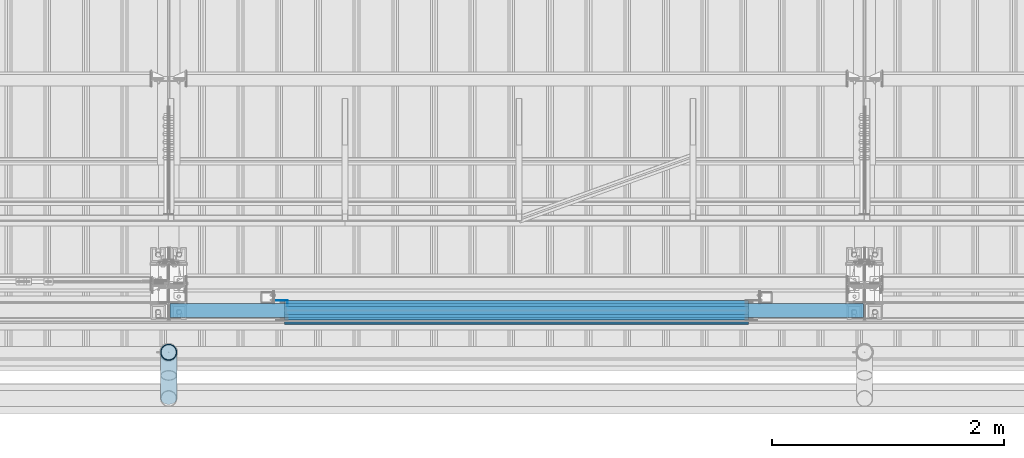
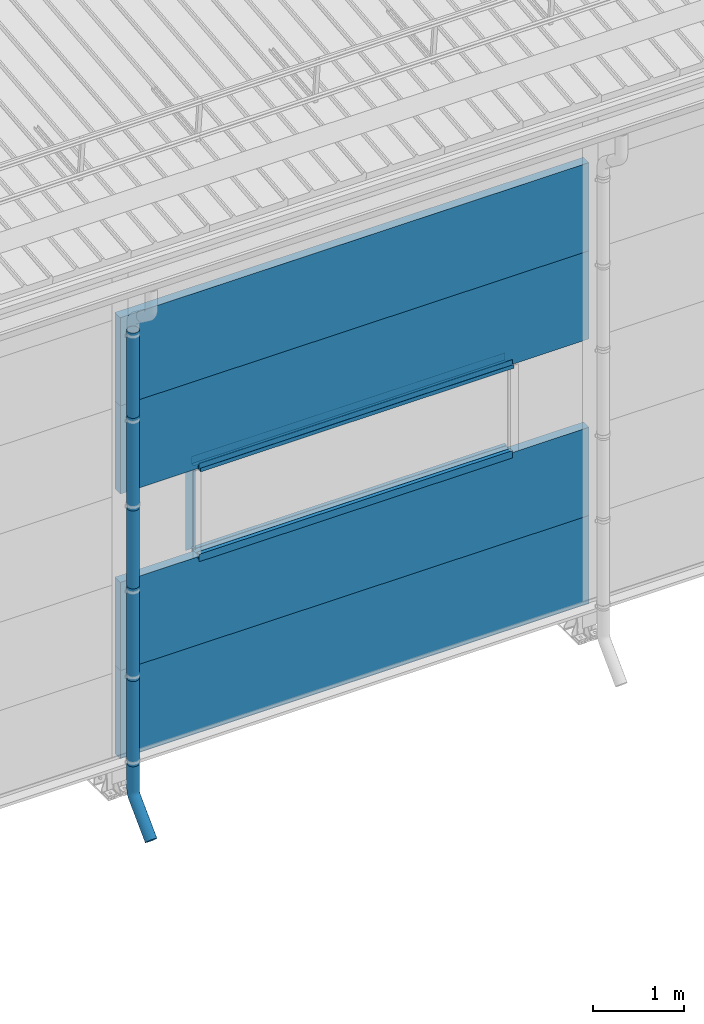
# One storey, part 45 of 709: 18 beams, 18 elements without a shape of their own.
"""IFC4 building model written with IfcOpenShell, lengths in millimetres."""

from ifc_helpers import new_model, entity, si_unit, direction, frame, origin_with_axes, place, context, subcontext, project, spatial, line, indexed_curve, outline, extrude, material, element, aggregate, save


model = new_model("IFC4")

# Units and contexts
model_context = context("Model", 3, precision=0.2, world=origin_with_axes(), true_north=direction((0.0, 1.0)))
body_context = subcontext(model_context, "Body", "Model", "MODEL_VIEW")
ifc_project = project(units=[si_unit("LENGTHUNIT", "METRE", prefix="MILLI"), si_unit("AREAUNIT", "SQUARE_METRE"), si_unit("VOLUMEUNIT", "CUBIC_METRE"), si_unit("MASSUNIT", "GRAM", prefix="KILO"), si_unit("TIMEUNIT", "SECOND"), si_unit("PLANEANGLEUNIT", "RADIAN"), si_unit("SOLIDANGLEUNIT", "STERADIAN"), si_unit("THERMODYNAMICTEMPERATUREUNIT", "DEGREE_CELSIUS"), si_unit("LUMINOUSINTENSITYUNIT", "LUMEN")], contexts=[model_context])

# Site, building, storey
site_placement = place(None, origin_with_axes())
site = spatial("IfcSite", under=ifc_project, at=site_placement, CompositionType="ELEMENT")
building_placement = place(site_placement, origin_with_axes())
building = spatial("IfcBuilding", under=site, at=building_placement, Name="Undefined", CompositionType="ELEMENT")
storey_placement = place(building_placement, origin_with_axes())
storey = spatial("IfcBuildingStorey", under=building, at=storey_placement, Name="Undefined", CompositionType="ELEMENT", Elevation=0.0)

# Assembly, beam
assembly_1_placement = place(storey_placement, frame((28010.0, -60.0, 895.0), z_axis=(0.0, 0.0, -1.0), x_axis=(1.0, 0.0, 0.0)))
assembly_1 = element("IfcElementAssembly", 1, at=assembly_1_placement, inside=storey)
ifc_material_1 = material(Name="Insulation", Category="Insulation")
beam_1_placement = place(assembly_1_placement, origin_with_axes())
beam_1 = element("IfcBeam", 2, at=beam_1_placement, material=ifc_material_1, ObjectType="P-107", context=body_context, shape_type="SolidModel", body=[
    extrude(outline(indexed_curve([(-595.0, -60.0), (595.0, -60.0), (595.0, 60.0), (-595.0, 60.0)], segments=[line(1, 2, 3, 4, 1)])), frame((0.0, 0.0, 0.0), z_axis=(-1.0, 0.0, 0.0), x_axis=(0.0, 0.0, 1.0)), (0.0, 0.0, -1.0), 5980.0),
])
aggregate(assembly_1, [beam_1])

assembly_2_placement = place(storey_placement, frame((28010.0, -60.0, 2085.0), z_axis=(0.0, 0.0, -1.0), x_axis=(1.0, 0.0, 0.0)))
assembly_2 = element("IfcElementAssembly", 3, at=assembly_2_placement, inside=storey)
beam_2_placement = place(assembly_2_placement, origin_with_axes())
beam_2 = element("IfcBeam", 4, at=beam_2_placement, material=ifc_material_1, ObjectType="P-107", context=body_context, shape_type="SolidModel", body=[
    extrude(outline(indexed_curve([(-595.0, -60.0), (595.0, -60.0), (595.0, 60.0), (-595.0, 60.0)], segments=[line(1, 2, 3, 4, 1)])), frame((0.0, 0.0, 0.0), z_axis=(-1.0, 0.0, 0.0), x_axis=(0.0, 0.0, 1.0)), (0.0, 0.0, -1.0), 5980.0),
])
aggregate(assembly_2, [beam_2])

assembly_3_placement = place(storey_placement, frame((28010.0, -60.0, 4465.0), z_axis=(0.0, 0.0, -1.0), x_axis=(1.0, 0.0, 0.0)))
assembly_3 = element("IfcElementAssembly", 5, at=assembly_3_placement, inside=storey)
beam_3_placement = place(assembly_3_placement, origin_with_axes())
beam_3 = element("IfcBeam", 6, at=beam_3_placement, material=ifc_material_1, ObjectType="P-107", context=body_context, shape_type="SolidModel", body=[
    extrude(outline(indexed_curve([(-595.0, -60.0), (595.0, -60.0), (595.0, 60.0), (-595.0, 60.0)], segments=[line(1, 2, 3, 4, 1)])), frame((0.0, 0.0, 0.0), z_axis=(-1.0, 0.0, 0.0), x_axis=(0.0, 0.0, 1.0)), (0.0, 0.0, -1.0), 5980.0),
])
aggregate(assembly_3, [beam_3])

assembly_4_placement = place(storey_placement, frame((28010.0, -60.0, 5655.0), z_axis=(0.0, 0.0, -1.0), x_axis=(1.0, 0.0, 0.0)))
assembly_4 = element("IfcElementAssembly", 7, at=assembly_4_placement, inside=storey)
beam_4_placement = place(assembly_4_placement, origin_with_axes())
beam_4 = element("IfcBeam", 8, at=beam_4_placement, material=ifc_material_1, ObjectType="P-107", context=body_context, shape_type="SolidModel", body=[
    extrude(outline(indexed_curve([(-595.0, -60.0), (595.0, -60.0), (595.0, 60.0), (-595.0, 60.0)], segments=[line(1, 2, 3, 4, 1)])), frame((0.0, 0.0, 0.0), z_axis=(-1.0, 0.0, 0.0), x_axis=(0.0, 0.0, 1.0)), (0.0, 0.0, -1.0), 5980.0),
])
aggregate(assembly_4, [beam_4])

assembly_5_placement = place(storey_placement, frame((29000.0, 1.0, 2725.0), z_axis=(0.0, 1.0, 0.0), x_axis=(1.0, 0.0, 0.0)))
assembly_5 = element("IfcElementAssembly", 9, at=assembly_5_placement, inside=storey)
ifc_material_2 = material(Name="Steel_Undefined", Category="STEEL")
beam_5_placement = place(assembly_5_placement, origin_with_axes())
beam_5 = element("IfcBeam", 10, at=beam_5_placement, material=ifc_material_2, context=body_context, shape_type="SolidModel", body=[
    extrude(outline(indexed_curve([(-25.0, -1.0), (25.0, -1.0), (25.0, 99.0), (23.0, 99.0), (23.0, 1.0), (-25.0, 1.0)], segments=[line(1, 2, 3, 4, 5, 6, 1)])), frame((0.0, 0.0, 0.0), z_axis=(-1.0, 0.0, 0.0), x_axis=(0.0, 0.0, 1.0)), (0.0, 0.0, -1.0), 4000.0),
])
aggregate(assembly_5, [beam_5])

assembly_6_placement = place(storey_placement, frame((33000.0, -60.0, 2680.0), z_axis=(0.0, 1.0, 0.0), x_axis=(-1.0, 0.0, 0.0)))
assembly_6 = element("IfcElementAssembly", 11, at=assembly_6_placement, inside=storey)
beam_6_placement = place(assembly_6_placement, origin_with_axes())
beam_6 = element("IfcBeam", 12, at=beam_6_placement, material=ifc_material_2, context=body_context, shape_type="SolidModel", body=[
    extrude(outline(indexed_curve([(-70.0, -25.0), (-68.0, -25.0), (-68.0, 23.0), (68.0, 23.0), (68.0, -25.0), (70.0, -25.0), (70.0, 25.0), (-70.0, 25.0)], segments=[line(1, 2, 3, 4, 5, 6, 7, 8, 1)])), frame((0.0, 0.0, 0.0), z_axis=(-1.0, 0.0, 0.0), x_axis=(0.0, 0.0, 1.0)), (0.0, 0.0, -1.0), 4000.0),
])
aggregate(assembly_6, [beam_6])

assembly_7_placement = place(storey_placement, frame((33000.0, -119.0, 2725.0), z_axis=(0.0, -1.0, 0.0), x_axis=(-1.0, 0.0, 0.0)))
assembly_7 = element("IfcElementAssembly", 13, at=assembly_7_placement, inside=storey)
beam_7_placement = place(assembly_7_placement, origin_with_axes())
beam_7 = element("IfcBeam", 14, at=beam_7_placement, material=ifc_material_2, context=body_context, shape_type="SolidModel", body=[
    extrude(outline(indexed_curve([(-25.0, -1.0), (25.0, -1.0), (25.0, 99.0), (23.0, 99.0), (23.0, 1.0), (-25.0, 1.0)], segments=[line(1, 2, 3, 4, 5, 6, 1)])), frame((0.0, 0.0, 0.0), z_axis=(-1.0, 0.0, 0.0), x_axis=(0.0, 0.0, 1.0)), (0.0, 0.0, -1.0), 4000.0),
])
aggregate(assembly_7, [beam_7])

assembly_8_placement = place(storey_placement, frame((33000.0, 1.0, 3845.0), z_axis=(0.0, 1.0, 0.0), x_axis=(-1.0, 0.0, 0.0)))
assembly_8 = element("IfcElementAssembly", 15, at=assembly_8_placement, inside=storey)
beam_8_placement = place(assembly_8_placement, origin_with_axes())
beam_8 = element("IfcBeam", 16, at=beam_8_placement, material=ifc_material_2, context=body_context, shape_type="SolidModel", body=[
    extrude(outline(indexed_curve([(-25.0, -1.0), (25.0, -1.0), (25.0, 99.0), (23.0, 99.0), (23.0, 1.0), (-25.0, 1.0)], segments=[line(1, 2, 3, 4, 5, 6, 1)])), frame((0.0, 0.0, 0.0), z_axis=(-1.0, 0.0, 0.0), x_axis=(0.0, 0.0, 1.0)), (0.0, 0.0, -1.0), 4000.0),
])
aggregate(assembly_8, [beam_8])

assembly_9_placement = place(storey_placement, frame((29000.0, -60.0, 3890.0), z_axis=(0.0, 1.0, 0.0), x_axis=(1.0, 0.0, 0.0)))
assembly_9 = element("IfcElementAssembly", 17, at=assembly_9_placement, inside=storey)
beam_9_placement = place(assembly_9_placement, origin_with_axes())
beam_9 = element("IfcBeam", 18, at=beam_9_placement, material=ifc_material_2, context=body_context, shape_type="SolidModel", body=[
    extrude(outline(indexed_curve([(-70.0, -25.0), (-68.0, -25.0), (-68.0, 23.0), (68.0, 23.0), (68.0, -25.0), (70.0, -25.0), (70.0, 25.0), (-70.0, 25.0)], segments=[line(1, 2, 3, 4, 5, 6, 7, 8, 1)])), frame((0.0, 0.0, 0.0), z_axis=(-1.0, 0.0, 0.0), x_axis=(0.0, 0.0, 1.0)), (0.0, 0.0, -1.0), 4000.0),
])
aggregate(assembly_9, [beam_9])

assembly_10_placement = place(storey_placement, frame((29000.0, -119.0, 3855.0), z_axis=(0.0, -1.0, 0.0), x_axis=(1.0, 0.0, 0.0)))
assembly_10 = element("IfcElementAssembly", 19, at=assembly_10_placement, inside=storey)
beam_10_placement = place(assembly_10_placement, origin_with_axes())
beam_10 = element("IfcBeam", 20, at=beam_10_placement, material=ifc_material_2, context=body_context, shape_type="SolidModel", body=[
    extrude(outline(indexed_curve([(-25.0, -1.0), (25.0, -1.0), (25.0, 99.0), (23.0, 99.0), (23.0, 1.0), (-25.0, 1.0)], segments=[line(1, 2, 3, 4, 5, 6, 1)])), frame((0.0, 0.0, 0.0), z_axis=(-1.0, 0.0, 0.0), x_axis=(0.0, 0.0, 1.0)), (0.0, 0.0, -1.0), 4000.0),
])
aggregate(assembly_10, [beam_10])

assembly_11_placement = place(storey_placement, frame((29000.0, -169.0, 3860.0), z_axis=(0.0, -1.0, 0.0), x_axis=(1.0, 0.0, 0.0)))
assembly_11 = element("IfcElementAssembly", 21, at=assembly_11_placement, inside=storey)
beam_11_placement = place(assembly_11_placement, origin_with_axes())
beam_11 = element("IfcBeam", 22, at=beam_11_placement, material=ifc_material_2, context=body_context, shape_type="SolidModel", body=[
    extrude(outline(indexed_curve([(-10.0, -1.0), (10.0, -1.0), (10.0, 49.0), (8.0, 49.0), (8.0, 1.0), (-10.0, 1.0)], segments=[line(1, 2, 3, 4, 5, 6, 1)])), frame((0.0, 0.0, 0.0), z_axis=(-1.0, 0.0, 0.0), x_axis=(0.0, 0.0, 1.0)), (0.0, 0.0, -1.0), 4000.0),
])
aggregate(assembly_11, [beam_11])

assembly_12_placement = place(storey_placement, frame((29025.0, 1.0, 3870.0), z_axis=(0.0, 1.0, 0.0), x_axis=(0.0, 0.0, -1.0)))
assembly_12 = element("IfcElementAssembly", 23, at=assembly_12_placement, inside=storey)
beam_12_placement = place(assembly_12_placement, origin_with_axes())
beam_12 = element("IfcBeam", 24, at=beam_12_placement, material=ifc_material_2, context=body_context, shape_type="SolidModel", body=[
    extrude(outline(indexed_curve([(-25.0, -1.0), (25.0, -1.0), (25.0, 99.0), (23.0, 99.0), (23.0, 1.0), (-25.0, 1.0)], segments=[line(1, 2, 3, 4, 5, 6, 1)])), frame((0.0, 0.0, 0.0), z_axis=(-1.0, 0.0, 0.0), x_axis=(0.0, 0.0, 1.0)), (0.0, 0.0, -1.0), 1170.0),
])
aggregate(assembly_12, [beam_12])

assembly_13_placement = place(storey_placement, frame((28000.0, -420.0, 6276.92297), z_axis=(0.0, 1.0, 0.0), x_axis=(0.0, 0.0, -1.0)))
assembly_13 = element("IfcElementAssembly", 25, at=assembly_13_placement, inside=storey)
beam_13_placement = place(assembly_13_placement, origin_with_axes())
beam_13 = element("IfcBeam", 26, at=beam_13_placement, material=ifc_material_2, ObjectType="614", context=body_context, shape_type="SolidModel", body=[
    extrude(outline(indexed_curve([(70.0, 0.0), (69.61653, 7.31699), (68.47033, 14.55382), (66.57396, 21.63119), (63.94818, 28.47157), (60.62178, 35.0), (56.63119, 41.14497), (52.02014, 46.83914), (46.83914, 52.02014), (41.14497, 56.63119), (35.0, 60.62178), (28.47157, 63.94818), (21.63119, 66.57396), (14.55382, 68.47033), (7.31699, 69.61653), (0.0, 70.0), (-7.31699, 69.61653), (-14.55382, 68.47033), (-21.63119, 66.57396), (-28.47157, 63.94818), (-35.0, 60.62178), (-41.14497, 56.63119), (-46.83914, 52.02014), (-52.02014, 46.83914), (-56.63119, 41.14497), (-60.62178, 35.0), (-63.94818, 28.47157), (-66.57396, 21.63119), (-68.47033, 14.55382), (-69.61653, 7.31699), (-70.0, 0.0), (-69.61653, -7.31699), (-68.47033, -14.55382), (-66.57396, -21.63119), (-63.94818, -28.47157), (-60.62178, -35.0), (-56.63119, -41.14497), (-52.02014, -46.83914), (-46.83914, -52.02014), (-41.14497, -56.63119), (-35.0, -60.62178), (-28.47157, -63.94818), (-21.63119, -66.57396), (-14.55382, -68.47033), (-7.31699, -69.61653), (0.0, -70.0), (7.31699, -69.61653), (14.55382, -68.47033), (21.63119, -66.57396), (28.47157, -63.94818), (35.0, -60.62178), (41.14497, -56.63119), (46.83914, -52.02014), (52.02014, -46.83914), (56.63119, -41.14497), (60.62178, -35.0), (63.94818, -28.47157), (66.57396, -21.63119), (68.47033, -14.55382), (69.61653, -7.31699)], segments=[line(1, 2, 3, 4, 5, 6, 7, 8, 9, 10, 11, 12, 13, 14, 15, 16, 17, 18, 19, 20, 21, 22, 23, 24, 25, 26, 27, 28, 29, 30, 31, 32, 33, 34, 35, 36, 37, 38, 39, 40, 41, 42, 43, 44, 45, 46, 47, 48, 49, 50, 51, 52, 53, 54, 55, 56, 57, 58, 59, 60, 1)]), holes=[indexed_curve([(65.0, 0.0), (64.64392, -6.79435), (63.57959, -13.51426), (61.81867, -20.0861), (59.38045, -26.43788), (56.29165, -32.5), (52.5861, -38.20604), (48.30441, -43.49349), (43.49349, -48.30441), (38.20604, -52.5861), (32.5, -56.29165), (26.43788, -59.38045), (20.0861, -61.81867), (13.51426, -63.57959), (6.79435, -64.64392), (0.0, -65.0), (-6.79435, -64.64392), (-13.51426, -63.57959), (-20.0861, -61.81867), (-26.43788, -59.38045), (-32.5, -56.29165), (-38.20604, -52.5861), (-43.49349, -48.30441), (-48.30441, -43.49349), (-52.5861, -38.20604), (-56.29165, -32.5), (-59.38045, -26.43788), (-61.81867, -20.0861), (-63.57959, -13.51426), (-64.64392, -6.79435), (-65.0, 0.0), (-64.64392, 6.79435), (-63.57959, 13.51426), (-61.81867, 20.0861), (-59.38045, 26.43788), (-56.29165, 32.5), (-52.5861, 38.20604), (-48.30441, 43.49349), (-43.49349, 48.30441), (-38.20604, 52.5861), (-32.5, 56.29165), (-26.43788, 59.38045), (-20.0861, 61.81867), (-13.51426, 63.57959), (-6.79435, 64.64392), (0.0, 65.0), (6.79435, 64.64392), (13.51426, 63.57959), (20.0861, 61.81867), (26.43788, 59.38045), (32.5, 56.29165), (38.20604, 52.5861), (43.49349, 48.30441), (48.30441, 43.49349), (52.5861, 38.20604), (56.29165, 32.5), (59.38045, 26.43788), (61.81867, 20.0861), (63.57959, 13.51426), (64.64392, 6.79435)], segments=[line(1, 2, 3, 4, 5, 6, 7, 8, 9, 10, 11, 12, 13, 14, 15, 16, 17, 18, 19, 20, 21, 22, 23, 24, 25, 26, 27, 28, 29, 30, 31, 32, 33, 34, 35, 36, 37, 38, 39, 40, 41, 42, 43, 44, 45, 46, 47, 48, 49, 50, 51, 52, 53, 54, 55, 56, 57, 58, 59, 60, 1)])]), frame((0.0, 0.0, 0.0), z_axis=(-1.0, 0.0, 0.0), x_axis=(0.0, 0.0, 1.0)), (0.0, 0.0, -1.0), 1250.0),
])
aggregate(assembly_13, [beam_13])

assembly_14_placement = place(storey_placement, frame((28000.0, -420.0, 5126.92297), z_axis=(0.0, 1.0, 0.0), x_axis=(0.0, 0.0, -1.0)))
assembly_14 = element("IfcElementAssembly", 27, at=assembly_14_placement, inside=storey)
beam_14_placement = place(assembly_14_placement, origin_with_axes())
beam_14 = element("IfcBeam", 28, at=beam_14_placement, material=ifc_material_2, ObjectType="614", context=body_context, shape_type="SolidModel", body=[
    extrude(outline(indexed_curve([(70.0, 0.0), (69.61653, 7.31699), (68.47033, 14.55382), (66.57396, 21.63119), (63.94818, 28.47157), (60.62178, 35.0), (56.63119, 41.14497), (52.02014, 46.83914), (46.83914, 52.02014), (41.14497, 56.63119), (35.0, 60.62178), (28.47157, 63.94818), (21.63119, 66.57396), (14.55382, 68.47033), (7.31699, 69.61653), (0.0, 70.0), (-7.31699, 69.61653), (-14.55382, 68.47033), (-21.63119, 66.57396), (-28.47157, 63.94818), (-35.0, 60.62178), (-41.14497, 56.63119), (-46.83914, 52.02014), (-52.02014, 46.83914), (-56.63119, 41.14497), (-60.62178, 35.0), (-63.94818, 28.47157), (-66.57396, 21.63119), (-68.47033, 14.55382), (-69.61653, 7.31699), (-70.0, 0.0), (-69.61653, -7.31699), (-68.47033, -14.55382), (-66.57396, -21.63119), (-63.94818, -28.47157), (-60.62178, -35.0), (-56.63119, -41.14497), (-52.02014, -46.83914), (-46.83914, -52.02014), (-41.14497, -56.63119), (-35.0, -60.62178), (-28.47157, -63.94818), (-21.63119, -66.57396), (-14.55382, -68.47033), (-7.31699, -69.61653), (0.0, -70.0), (7.31699, -69.61653), (14.55382, -68.47033), (21.63119, -66.57396), (28.47157, -63.94818), (35.0, -60.62178), (41.14497, -56.63119), (46.83914, -52.02014), (52.02014, -46.83914), (56.63119, -41.14497), (60.62178, -35.0), (63.94818, -28.47157), (66.57396, -21.63119), (68.47033, -14.55382), (69.61653, -7.31699)], segments=[line(1, 2, 3, 4, 5, 6, 7, 8, 9, 10, 11, 12, 13, 14, 15, 16, 17, 18, 19, 20, 21, 22, 23, 24, 25, 26, 27, 28, 29, 30, 31, 32, 33, 34, 35, 36, 37, 38, 39, 40, 41, 42, 43, 44, 45, 46, 47, 48, 49, 50, 51, 52, 53, 54, 55, 56, 57, 58, 59, 60, 1)]), holes=[indexed_curve([(65.0, 0.0), (64.64392, -6.79435), (63.57959, -13.51426), (61.81867, -20.0861), (59.38045, -26.43788), (56.29165, -32.5), (52.5861, -38.20604), (48.30441, -43.49349), (43.49349, -48.30441), (38.20604, -52.5861), (32.5, -56.29165), (26.43788, -59.38045), (20.0861, -61.81867), (13.51426, -63.57959), (6.79435, -64.64392), (0.0, -65.0), (-6.79435, -64.64392), (-13.51426, -63.57959), (-20.0861, -61.81867), (-26.43788, -59.38045), (-32.5, -56.29165), (-38.20604, -52.5861), (-43.49349, -48.30441), (-48.30441, -43.49349), (-52.5861, -38.20604), (-56.29165, -32.5), (-59.38045, -26.43788), (-61.81867, -20.0861), (-63.57959, -13.51426), (-64.64392, -6.79435), (-65.0, 0.0), (-64.64392, 6.79435), (-63.57959, 13.51426), (-61.81867, 20.0861), (-59.38045, 26.43788), (-56.29165, 32.5), (-52.5861, 38.20604), (-48.30441, 43.49349), (-43.49349, 48.30441), (-38.20604, 52.5861), (-32.5, 56.29165), (-26.43788, 59.38045), (-20.0861, 61.81867), (-13.51426, 63.57959), (-6.79435, 64.64392), (0.0, 65.0), (6.79435, 64.64392), (13.51426, 63.57959), (20.0861, 61.81867), (26.43788, 59.38045), (32.5, 56.29165), (38.20604, 52.5861), (43.49349, 48.30441), (48.30441, 43.49349), (52.5861, 38.20604), (56.29165, 32.5), (59.38045, 26.43788), (61.81867, 20.0861), (63.57959, 13.51426), (64.64392, 6.79435)], segments=[line(1, 2, 3, 4, 5, 6, 7, 8, 9, 10, 11, 12, 13, 14, 15, 16, 17, 18, 19, 20, 21, 22, 23, 24, 25, 26, 27, 28, 29, 30, 31, 32, 33, 34, 35, 36, 37, 38, 39, 40, 41, 42, 43, 44, 45, 46, 47, 48, 49, 50, 51, 52, 53, 54, 55, 56, 57, 58, 59, 60, 1)])]), frame((0.0, 0.0, 0.0), z_axis=(-1.0, 0.0, 0.0), x_axis=(0.0, 0.0, 1.0)), (0.0, 0.0, -1.0), 1250.0),
])
aggregate(assembly_14, [beam_14])

assembly_15_placement = place(storey_placement, frame((28000.0, -420.0, 3976.92297), z_axis=(0.0, 1.0, 0.0), x_axis=(0.0, 0.0, -1.0)))
assembly_15 = element("IfcElementAssembly", 29, at=assembly_15_placement, inside=storey)
beam_15_placement = place(assembly_15_placement, origin_with_axes())
beam_15 = element("IfcBeam", 30, at=beam_15_placement, material=ifc_material_2, ObjectType="614", context=body_context, shape_type="SolidModel", body=[
    extrude(outline(indexed_curve([(70.0, 0.0), (69.61653, 7.31699), (68.47033, 14.55382), (66.57396, 21.63119), (63.94818, 28.47157), (60.62178, 35.0), (56.63119, 41.14497), (52.02014, 46.83914), (46.83914, 52.02014), (41.14497, 56.63119), (35.0, 60.62178), (28.47157, 63.94818), (21.63119, 66.57396), (14.55382, 68.47033), (7.31699, 69.61653), (0.0, 70.0), (-7.31699, 69.61653), (-14.55382, 68.47033), (-21.63119, 66.57396), (-28.47157, 63.94818), (-35.0, 60.62178), (-41.14497, 56.63119), (-46.83914, 52.02014), (-52.02014, 46.83914), (-56.63119, 41.14497), (-60.62178, 35.0), (-63.94818, 28.47157), (-66.57396, 21.63119), (-68.47033, 14.55382), (-69.61653, 7.31699), (-70.0, 0.0), (-69.61653, -7.31699), (-68.47033, -14.55382), (-66.57396, -21.63119), (-63.94818, -28.47157), (-60.62178, -35.0), (-56.63119, -41.14497), (-52.02014, -46.83914), (-46.83914, -52.02014), (-41.14497, -56.63119), (-35.0, -60.62178), (-28.47157, -63.94818), (-21.63119, -66.57396), (-14.55382, -68.47033), (-7.31699, -69.61653), (0.0, -70.0), (7.31699, -69.61653), (14.55382, -68.47033), (21.63119, -66.57396), (28.47157, -63.94818), (35.0, -60.62178), (41.14497, -56.63119), (46.83914, -52.02014), (52.02014, -46.83914), (56.63119, -41.14497), (60.62178, -35.0), (63.94818, -28.47157), (66.57396, -21.63119), (68.47033, -14.55382), (69.61653, -7.31699)], segments=[line(1, 2, 3, 4, 5, 6, 7, 8, 9, 10, 11, 12, 13, 14, 15, 16, 17, 18, 19, 20, 21, 22, 23, 24, 25, 26, 27, 28, 29, 30, 31, 32, 33, 34, 35, 36, 37, 38, 39, 40, 41, 42, 43, 44, 45, 46, 47, 48, 49, 50, 51, 52, 53, 54, 55, 56, 57, 58, 59, 60, 1)]), holes=[indexed_curve([(65.0, 0.0), (64.64392, -6.79435), (63.57959, -13.51426), (61.81867, -20.0861), (59.38045, -26.43788), (56.29165, -32.5), (52.5861, -38.20604), (48.30441, -43.49349), (43.49349, -48.30441), (38.20604, -52.5861), (32.5, -56.29165), (26.43788, -59.38045), (20.0861, -61.81867), (13.51426, -63.57959), (6.79435, -64.64392), (0.0, -65.0), (-6.79435, -64.64392), (-13.51426, -63.57959), (-20.0861, -61.81867), (-26.43788, -59.38045), (-32.5, -56.29165), (-38.20604, -52.5861), (-43.49349, -48.30441), (-48.30441, -43.49349), (-52.5861, -38.20604), (-56.29165, -32.5), (-59.38045, -26.43788), (-61.81867, -20.0861), (-63.57959, -13.51426), (-64.64392, -6.79435), (-65.0, 0.0), (-64.64392, 6.79435), (-63.57959, 13.51426), (-61.81867, 20.0861), (-59.38045, 26.43788), (-56.29165, 32.5), (-52.5861, 38.20604), (-48.30441, 43.49349), (-43.49349, 48.30441), (-38.20604, 52.5861), (-32.5, 56.29165), (-26.43788, 59.38045), (-20.0861, 61.81867), (-13.51426, 63.57959), (-6.79435, 64.64392), (0.0, 65.0), (6.79435, 64.64392), (13.51426, 63.57959), (20.0861, 61.81867), (26.43788, 59.38045), (32.5, 56.29165), (38.20604, 52.5861), (43.49349, 48.30441), (48.30441, 43.49349), (52.5861, 38.20604), (56.29165, 32.5), (59.38045, 26.43788), (61.81867, 20.0861), (63.57959, 13.51426), (64.64392, 6.79435)], segments=[line(1, 2, 3, 4, 5, 6, 7, 8, 9, 10, 11, 12, 13, 14, 15, 16, 17, 18, 19, 20, 21, 22, 23, 24, 25, 26, 27, 28, 29, 30, 31, 32, 33, 34, 35, 36, 37, 38, 39, 40, 41, 42, 43, 44, 45, 46, 47, 48, 49, 50, 51, 52, 53, 54, 55, 56, 57, 58, 59, 60, 1)])]), frame((0.0, 0.0, 0.0), z_axis=(-1.0, 0.0, 0.0), x_axis=(0.0, 0.0, 1.0)), (0.0, 0.0, -1.0), 1250.0),
])
aggregate(assembly_15, [beam_15])

assembly_16_placement = place(storey_placement, frame((28000.0, -420.0, 2826.92297), z_axis=(0.0, 1.0, 0.0), x_axis=(0.0, 0.0, -1.0)))
assembly_16 = element("IfcElementAssembly", 31, at=assembly_16_placement, inside=storey)
beam_16_placement = place(assembly_16_placement, origin_with_axes())
beam_16 = element("IfcBeam", 32, at=beam_16_placement, material=ifc_material_2, ObjectType="614", context=body_context, shape_type="SolidModel", body=[
    extrude(outline(indexed_curve([(70.0, 0.0), (69.61653, 7.31699), (68.47033, 14.55382), (66.57396, 21.63119), (63.94818, 28.47157), (60.62178, 35.0), (56.63119, 41.14497), (52.02014, 46.83914), (46.83914, 52.02014), (41.14497, 56.63119), (35.0, 60.62178), (28.47157, 63.94818), (21.63119, 66.57396), (14.55382, 68.47033), (7.31699, 69.61653), (0.0, 70.0), (-7.31699, 69.61653), (-14.55382, 68.47033), (-21.63119, 66.57396), (-28.47157, 63.94818), (-35.0, 60.62178), (-41.14497, 56.63119), (-46.83914, 52.02014), (-52.02014, 46.83914), (-56.63119, 41.14497), (-60.62178, 35.0), (-63.94818, 28.47157), (-66.57396, 21.63119), (-68.47033, 14.55382), (-69.61653, 7.31699), (-70.0, 0.0), (-69.61653, -7.31699), (-68.47033, -14.55382), (-66.57396, -21.63119), (-63.94818, -28.47157), (-60.62178, -35.0), (-56.63119, -41.14497), (-52.02014, -46.83914), (-46.83914, -52.02014), (-41.14497, -56.63119), (-35.0, -60.62178), (-28.47157, -63.94818), (-21.63119, -66.57396), (-14.55382, -68.47033), (-7.31699, -69.61653), (0.0, -70.0), (7.31699, -69.61653), (14.55382, -68.47033), (21.63119, -66.57396), (28.47157, -63.94818), (35.0, -60.62178), (41.14497, -56.63119), (46.83914, -52.02014), (52.02014, -46.83914), (56.63119, -41.14497), (60.62178, -35.0), (63.94818, -28.47157), (66.57396, -21.63119), (68.47033, -14.55382), (69.61653, -7.31699)], segments=[line(1, 2, 3, 4, 5, 6, 7, 8, 9, 10, 11, 12, 13, 14, 15, 16, 17, 18, 19, 20, 21, 22, 23, 24, 25, 26, 27, 28, 29, 30, 31, 32, 33, 34, 35, 36, 37, 38, 39, 40, 41, 42, 43, 44, 45, 46, 47, 48, 49, 50, 51, 52, 53, 54, 55, 56, 57, 58, 59, 60, 1)]), holes=[indexed_curve([(65.0, 0.0), (64.64392, -6.79435), (63.57959, -13.51426), (61.81867, -20.0861), (59.38045, -26.43788), (56.29165, -32.5), (52.5861, -38.20604), (48.30441, -43.49349), (43.49349, -48.30441), (38.20604, -52.5861), (32.5, -56.29165), (26.43788, -59.38045), (20.0861, -61.81867), (13.51426, -63.57959), (6.79435, -64.64392), (0.0, -65.0), (-6.79435, -64.64392), (-13.51426, -63.57959), (-20.0861, -61.81867), (-26.43788, -59.38045), (-32.5, -56.29165), (-38.20604, -52.5861), (-43.49349, -48.30441), (-48.30441, -43.49349), (-52.5861, -38.20604), (-56.29165, -32.5), (-59.38045, -26.43788), (-61.81867, -20.0861), (-63.57959, -13.51426), (-64.64392, -6.79435), (-65.0, 0.0), (-64.64392, 6.79435), (-63.57959, 13.51426), (-61.81867, 20.0861), (-59.38045, 26.43788), (-56.29165, 32.5), (-52.5861, 38.20604), (-48.30441, 43.49349), (-43.49349, 48.30441), (-38.20604, 52.5861), (-32.5, 56.29165), (-26.43788, 59.38045), (-20.0861, 61.81867), (-13.51426, 63.57959), (-6.79435, 64.64392), (0.0, 65.0), (6.79435, 64.64392), (13.51426, 63.57959), (20.0861, 61.81867), (26.43788, 59.38045), (32.5, 56.29165), (38.20604, 52.5861), (43.49349, 48.30441), (48.30441, 43.49349), (52.5861, 38.20604), (56.29165, 32.5), (59.38045, 26.43788), (61.81867, 20.0861), (63.57959, 13.51426), (64.64392, 6.79435)], segments=[line(1, 2, 3, 4, 5, 6, 7, 8, 9, 10, 11, 12, 13, 14, 15, 16, 17, 18, 19, 20, 21, 22, 23, 24, 25, 26, 27, 28, 29, 30, 31, 32, 33, 34, 35, 36, 37, 38, 39, 40, 41, 42, 43, 44, 45, 46, 47, 48, 49, 50, 51, 52, 53, 54, 55, 56, 57, 58, 59, 60, 1)])]), frame((0.0, 0.0, 0.0), z_axis=(-1.0, 0.0, 0.0), x_axis=(0.0, 0.0, 1.0)), (0.0, 0.0, -1.0), 1250.0),
])
aggregate(assembly_16, [beam_16])

assembly_17_placement = place(storey_placement, frame((28000.0, -420.0, 1676.92297), z_axis=(0.0, 1.0, 0.0), x_axis=(0.0, 0.0, -1.0)))
assembly_17 = element("IfcElementAssembly", 33, at=assembly_17_placement, inside=storey)
beam_17_placement = place(assembly_17_placement, origin_with_axes())
beam_17 = element("IfcBeam", 34, at=beam_17_placement, material=ifc_material_2, ObjectType="614", context=body_context, shape_type="SolidModel", body=[
    extrude(outline(indexed_curve([(70.0, 0.0), (69.61653, 7.31699), (68.47033, 14.55382), (66.57396, 21.63119), (63.94818, 28.47157), (60.62178, 35.0), (56.63119, 41.14497), (52.02014, 46.83914), (46.83914, 52.02014), (41.14497, 56.63119), (35.0, 60.62178), (28.47157, 63.94818), (21.63119, 66.57396), (14.55382, 68.47033), (7.31699, 69.61653), (0.0, 70.0), (-7.31699, 69.61653), (-14.55382, 68.47033), (-21.63119, 66.57396), (-28.47157, 63.94818), (-35.0, 60.62178), (-41.14497, 56.63119), (-46.83914, 52.02014), (-52.02014, 46.83914), (-56.63119, 41.14497), (-60.62178, 35.0), (-63.94818, 28.47157), (-66.57396, 21.63119), (-68.47033, 14.55382), (-69.61653, 7.31699), (-70.0, 0.0), (-69.61653, -7.31699), (-68.47033, -14.55382), (-66.57396, -21.63119), (-63.94818, -28.47157), (-60.62178, -35.0), (-56.63119, -41.14497), (-52.02014, -46.83914), (-46.83914, -52.02014), (-41.14497, -56.63119), (-35.0, -60.62178), (-28.47157, -63.94818), (-21.63119, -66.57396), (-14.55382, -68.47033), (-7.31699, -69.61653), (0.0, -70.0), (7.31699, -69.61653), (14.55382, -68.47033), (21.63119, -66.57396), (28.47157, -63.94818), (35.0, -60.62178), (41.14497, -56.63119), (46.83914, -52.02014), (52.02014, -46.83914), (56.63119, -41.14497), (60.62178, -35.0), (63.94818, -28.47157), (66.57396, -21.63119), (68.47033, -14.55382), (69.61653, -7.31699)], segments=[line(1, 2, 3, 4, 5, 6, 7, 8, 9, 10, 11, 12, 13, 14, 15, 16, 17, 18, 19, 20, 21, 22, 23, 24, 25, 26, 27, 28, 29, 30, 31, 32, 33, 34, 35, 36, 37, 38, 39, 40, 41, 42, 43, 44, 45, 46, 47, 48, 49, 50, 51, 52, 53, 54, 55, 56, 57, 58, 59, 60, 1)]), holes=[indexed_curve([(65.0, 0.0), (64.64392, -6.79435), (63.57959, -13.51426), (61.81867, -20.0861), (59.38045, -26.43788), (56.29165, -32.5), (52.5861, -38.20604), (48.30441, -43.49349), (43.49349, -48.30441), (38.20604, -52.5861), (32.5, -56.29165), (26.43788, -59.38045), (20.0861, -61.81867), (13.51426, -63.57959), (6.79435, -64.64392), (0.0, -65.0), (-6.79435, -64.64392), (-13.51426, -63.57959), (-20.0861, -61.81867), (-26.43788, -59.38045), (-32.5, -56.29165), (-38.20604, -52.5861), (-43.49349, -48.30441), (-48.30441, -43.49349), (-52.5861, -38.20604), (-56.29165, -32.5), (-59.38045, -26.43788), (-61.81867, -20.0861), (-63.57959, -13.51426), (-64.64392, -6.79435), (-65.0, 0.0), (-64.64392, 6.79435), (-63.57959, 13.51426), (-61.81867, 20.0861), (-59.38045, 26.43788), (-56.29165, 32.5), (-52.5861, 38.20604), (-48.30441, 43.49349), (-43.49349, 48.30441), (-38.20604, 52.5861), (-32.5, 56.29165), (-26.43788, 59.38045), (-20.0861, 61.81867), (-13.51426, 63.57959), (-6.79435, 64.64392), (0.0, 65.0), (6.79435, 64.64392), (13.51426, 63.57959), (20.0861, 61.81867), (26.43788, 59.38045), (32.5, 56.29165), (38.20604, 52.5861), (43.49349, 48.30441), (48.30441, 43.49349), (52.5861, 38.20604), (56.29165, 32.5), (59.38045, 26.43788), (61.81867, 20.0861), (63.57959, 13.51426), (64.64392, 6.79435)], segments=[line(1, 2, 3, 4, 5, 6, 7, 8, 9, 10, 11, 12, 13, 14, 15, 16, 17, 18, 19, 20, 21, 22, 23, 24, 25, 26, 27, 28, 29, 30, 31, 32, 33, 34, 35, 36, 37, 38, 39, 40, 41, 42, 43, 44, 45, 46, 47, 48, 49, 50, 51, 52, 53, 54, 55, 56, 57, 58, 59, 60, 1)])]), frame((0.0, 0.0, 0.0), z_axis=(-1.0, 0.0, 0.0), x_axis=(0.0, 0.0, 1.0)), (0.0, 0.0, -1.0), 1250.0),
])
aggregate(assembly_17, [beam_17])

assembly_18_placement = place(storey_placement, frame((28000.0, -420.0, 526.92297), z_axis=(-1.0, 0.0, 0.0), x_axis=(0.0, 0.0, -1.0)))
assembly_18 = element("IfcElementAssembly", 35, at=assembly_18_placement, inside=storey)
beam_18_placement = place(assembly_18_placement, origin_with_axes())
beam_18 = element("IfcBeam", 36, at=beam_18_placement, material=ifc_material_2, ObjectType="617", context=body_context, shape_type="SolidModel", body=[
    entity("IfcSweptDiskSolid", entity("IfcIndexedPolyCurve", entity("IfcCartesianPointList3D", [[0.0, 0.0, 0.0], [448.2233, 0.0, 0.0], [496.05873, 9.51506, 0.0], [536.61165, 36.61165, 0.0], [900.0, 400.0, 0.0]]), [entity("IfcLineIndex", [1, 2]), entity("IfcArcIndex", [2, 3, 4]), entity("IfcLineIndex", [4, 5])]), 70.0, 65.0),
])
aggregate(assembly_18, [beam_18])

save(model, "model.ifc")
